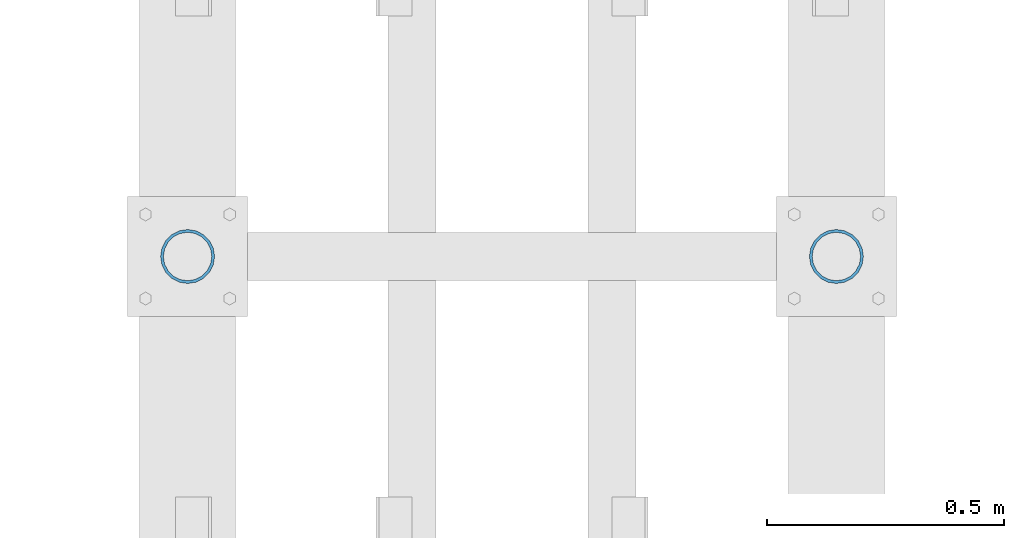
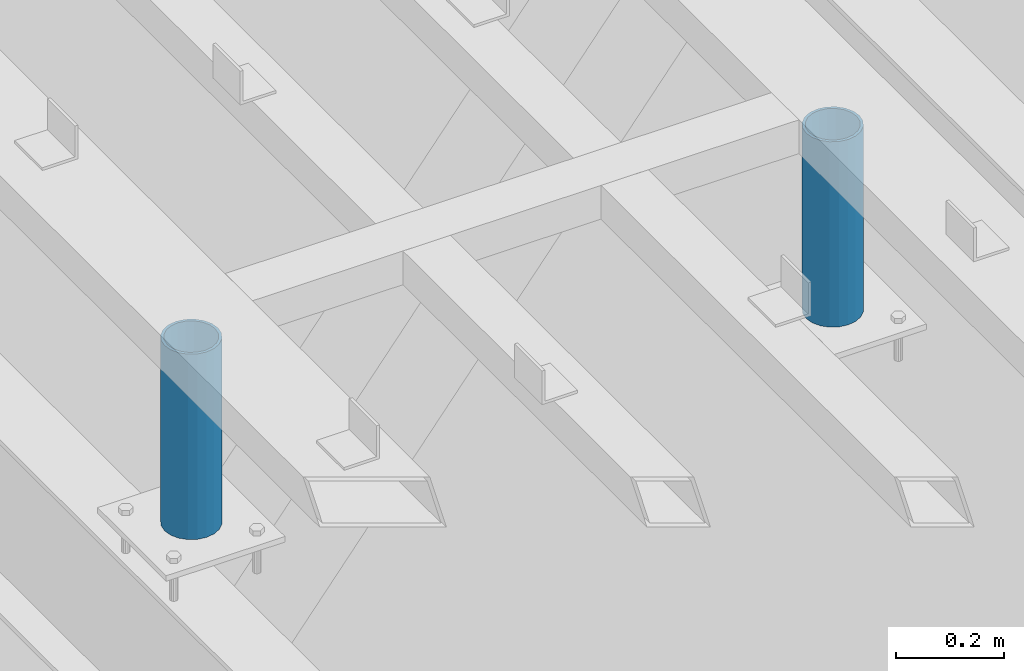
# One storey, part 502 of 1179: 2 columns, 1 element without a shape of its own.
"""IFC2X3 building model written with IfcOpenShell, lengths in millimetres."""

from ifc_helpers import new_model, si_unit, frame, origin_with_axes, place, context, subcontext, project, spatial, faceted_brep, material, type_object, element, aggregate, save


model = new_model("IFC2X3")

# Units and contexts
model_context = context("Model", 3, precision=1e-05, world=origin_with_axes())
body_context = subcontext(model_context, "Body", "Model", "MODEL_VIEW")
ifc_project = project(units=[si_unit("LENGTHUNIT", "METRE", prefix="MILLI"), si_unit("AREAUNIT", "SQUARE_METRE"), si_unit("VOLUMEUNIT", "CUBIC_METRE"), si_unit("MASSUNIT", "GRAM", prefix="KILO"), si_unit("TIMEUNIT", "SECOND"), si_unit("PLANEANGLEUNIT", "RADIAN"), si_unit("SOLIDANGLEUNIT", "STERADIAN"), si_unit("THERMODYNAMICTEMPERATUREUNIT", "DEGREE_CELSIUS"), si_unit("LUMINOUSINTENSITYUNIT", "LUMEN")], contexts=[model_context])

# Site, building, storey
site_placement = place(None, origin_with_axes())
site = spatial("IfcSite", under=ifc_project, at=site_placement, CompositionType="ELEMENT")
building_placement = place(site_placement, origin_with_axes())
building = spatial("IfcBuilding", under=site, at=building_placement, Name="Undefined", CompositionType="ELEMENT")
storey_placement = place(building_placement, origin_with_axes())
storey = spatial("IfcBuildingStorey", under=building, at=storey_placement, Name="Undefined", CompositionType="ELEMENT", Elevation=0.0)

# Assembly, columns
assembly_placement = place(storey_placement, origin_with_axes())
assembly = element("IfcElementAssembly", 1, at=assembly_placement, inside=storey, Name="FRAME", AssemblyPlace="NOTDEFINED", PredefinedType="RIGID_FRAME")
ifc_material = material()
column_type = type_object("IfcColumnType", Name="PIPE4SCH40", PredefinedType="NOTDEFINED")
column_1_placement = place(assembly_placement, frame((9652.0, 37794.5344873485, 13265.15), z_axis=(0.0, 1.0, 0.0), x_axis=(0.0, 0.0, 1.0)))
column_1 = element("IfcColumn", 2, at=column_1_placement, type_object=column_type, material=ifc_material, Name="COLUMN", ObjectType="PIPE4SCH40", context=body_context, shape_type="Brep", body=[
    faceted_brep([(0.0, -51.1301999999996, 0.0), (0.0, -48.6277098894752, 15.8001007257917), (419.099999999999, -48.6277098894752, 15.8001007257917), (419.099999999999, -51.1301999999996, 0.0), (0.0, -41.3652007257915, 30.0535775067619), (419.099999999999, -41.3652007257915, 30.0535775067619), (0.0, -30.0535775067656, 41.3652007257915), (419.099999999999, -30.0535775067656, 41.3652007257915), (0.0, -15.8001007257917, 48.6277098894716), (419.099999999999, -15.8001007257917, 48.6277098894716), (0.0, 0.0, 51.1301999999996), (419.099999999999, 0.0, 51.1301999999996), (0.0, 15.8001007257917, 48.6277098894716), (419.099999999999, 15.8001007257917, 48.6277098894716), (0.0, 30.0535775067656, 41.3652007257915), (419.099999999999, 30.0535775067656, 41.3652007257915), (0.0, 41.3652007257915, 30.0535775067619), (419.099999999999, 41.3652007257915, 30.0535775067619), (0.0, 48.6277098894752, 15.8001007257917), (419.099999999999, 48.6277098894752, 15.8001007257917), (0.0, 51.1301999999996, 0.0), (419.099999999999, 51.1301999999996, 0.0), (0.0, 48.6277098894752, -15.8001007257917), (419.099999999999, 48.6277098894752, -15.8001007257917), (0.0, 41.3652007257915, -30.0535775067619), (419.099999999999, 41.3652007257915, -30.0535775067619), (0.0, 30.0535775067656, -41.3652007257915), (419.099999999999, 30.0535775067656, -41.3652007257915), (0.0, 15.8001007257917, -48.6277098894716), (419.099999999999, 15.8001007257917, -48.6277098894716), (0.0, 0.0, -51.1301999999996), (419.099999999999, 0.0, -51.1301999999996), (0.0, -15.8001007257917, -48.6277098894716), (419.099999999999, -15.8001007257917, -48.6277098894716), (0.0, -30.0535775067656, -41.3652007257915), (419.099999999999, -30.0535775067656, -41.3652007257915), (0.0, -41.3652007257915, -30.0535775067619), (419.099999999999, -41.3652007257915, -30.0535775067619), (0.0, -48.6277098894752, -15.8001007257917), (419.099999999999, -48.6277098894752, -15.8001007257917), (0.0, -57.1500000000015, 0.0), (0.0, -54.3528799062697, -17.6603212285263), (419.099999999999, -54.3528799062697, -17.6603212285263), (419.099999999999, -57.1500000000015, 0.0), (0.0, -46.235321228527, -33.5919271685125), (419.099999999999, -46.235321228527, -33.5919271685125), (0.0, -33.5919271685161, -46.2353212285307), (419.099999999999, -33.5919271685161, -46.2353212285307), (0.0, -17.6603212285299, -54.3528799062697), (419.099999999999, -17.6603212285299, -54.3528799062697), (0.0, 0.0, -57.1500000000015), (419.099999999999, 0.0, -57.1500000000015), (0.0, 17.6603212285299, -54.3528799062697), (419.099999999999, 17.6603212285299, -54.3528799062697), (0.0, 33.5919271685161, -46.2353212285307), (419.099999999999, 33.5919271685161, -46.2353212285307), (0.0, 46.235321228527, -33.5919271685125), (419.099999999999, 46.235321228527, -33.5919271685125), (0.0, 54.3528799062697, -17.6603212285263), (419.099999999999, 54.3528799062697, -17.6603212285263), (0.0, 57.1500000000015, 0.0), (419.099999999999, 57.1500000000015, 0.0), (0.0, 54.3528799062697, 17.6603212285263), (419.099999999999, 54.3528799062697, 17.6603212285263), (0.0, 46.235321228527, 33.5919271685125), (419.099999999999, 46.235321228527, 33.5919271685125), (0.0, 33.5919271685161, 46.2353212285307), (419.099999999999, 33.5919271685161, 46.2353212285307), (0.0, 17.6603212285299, 54.3528799062697), (419.099999999999, 17.6603212285299, 54.3528799062697), (0.0, 0.0, 57.1500000000015), (419.099999999999, 0.0, 57.1500000000015), (0.0, -17.6603212285299, 54.3528799062697), (419.099999999999, -17.6603212285299, 54.3528799062697), (0.0, -33.5919271685161, 46.2353212285307), (419.099999999999, -33.5919271685161, 46.2353212285307), (0.0, -46.235321228527, 33.5919271685125), (419.099999999999, -46.235321228527, 33.5919271685125), (0.0, -54.3528799062697, 17.6603212285263), (419.099999999999, -54.3528799062697, 17.6603212285263)], [[[0, 1, 2, 3]], [[1, 4, 5, 2]], [[4, 6, 7, 5]], [[6, 8, 9, 7]], [[8, 10, 11, 9]], [[10, 12, 13, 11]], [[12, 14, 15, 13]], [[14, 16, 17, 15]], [[16, 18, 19, 17]], [[18, 20, 21, 19]], [[20, 22, 23, 21]], [[22, 24, 25, 23]], [[24, 26, 27, 25]], [[26, 28, 29, 27]], [[28, 30, 31, 29]], [[30, 32, 33, 31]], [[32, 34, 35, 33]], [[34, 36, 37, 35]], [[36, 38, 39, 37]], [[38, 0, 3, 39]], [[40, 41, 42, 43]], [[41, 44, 45, 42]], [[44, 46, 47, 45]], [[46, 48, 49, 47]], [[48, 50, 51, 49]], [[50, 52, 53, 51]], [[52, 54, 55, 53]], [[54, 56, 57, 55]], [[56, 58, 59, 57]], [[58, 60, 61, 59]], [[60, 62, 63, 61]], [[62, 64, 65, 63]], [[64, 66, 67, 65]], [[66, 68, 69, 67]], [[68, 70, 71, 69]], [[70, 72, 73, 71]], [[72, 74, 75, 73]], [[74, 76, 77, 75]], [[76, 78, 79, 77]], [[78, 40, 43, 79]], [[45, 47, 49, 51, 53, 55, 57, 59, 61, 63, 65, 67, 69, 71, 73, 75, 77, 79, 43, 42], [5, 7, 9, 11, 13, 15, 17, 19, 21, 23, 25, 27, 29, 31, 33, 35, 37, 39, 3, 2]], [[78, 76, 74, 72, 70, 68, 66, 64, 62, 60, 58, 56, 54, 52, 50, 48, 46, 44, 41, 40], [38, 36, 34, 32, 30, 28, 26, 24, 22, 20, 18, 16, 14, 12, 10, 8, 6, 4, 1, 0]]]),
])
column_2_placement = place(assembly_placement, frame((8280.4, 37794.5344873485, 13265.15), z_axis=(0.0, 1.0, 0.0), x_axis=(0.0, 0.0, 1.0)))
column_2 = element("IfcColumn", 3, at=column_2_placement, type_object=column_type, material=ifc_material, Name="COLUMN", ObjectType="PIPE4SCH40", context=body_context, shape_type="Brep", body=[
    faceted_brep([(0.0, -51.1301999999996, 0.0), (0.0, -48.6277098894752, 15.8001007257917), (419.099999999999, -48.6277098894752, 15.8001007257917), (419.099999999999, -51.1301999999996, 0.0), (0.0, -41.3652007257915, 30.0535775067619), (419.099999999999, -41.3652007257915, 30.0535775067619), (0.0, -30.0535775067656, 41.3652007257915), (419.099999999999, -30.0535775067656, 41.3652007257915), (0.0, -15.8001007257917, 48.6277098894716), (419.099999999999, -15.8001007257917, 48.6277098894716), (0.0, 0.0, 51.1301999999996), (419.099999999999, 0.0, 51.1301999999996), (0.0, 15.8001007257917, 48.6277098894716), (419.099999999999, 15.8001007257917, 48.6277098894716), (0.0, 30.0535775067656, 41.3652007257915), (419.099999999999, 30.0535775067656, 41.3652007257915), (0.0, 41.3652007257915, 30.0535775067619), (419.099999999999, 41.3652007257915, 30.0535775067619), (0.0, 48.6277098894752, 15.8001007257917), (419.099999999999, 48.6277098894752, 15.8001007257917), (0.0, 51.1301999999996, 0.0), (419.099999999999, 51.1301999999996, 0.0), (0.0, 48.6277098894752, -15.8001007257917), (419.099999999999, 48.6277098894752, -15.8001007257917), (0.0, 41.3652007257915, -30.0535775067619), (419.099999999999, 41.3652007257915, -30.0535775067619), (0.0, 30.0535775067656, -41.3652007257915), (419.099999999999, 30.0535775067656, -41.3652007257915), (0.0, 15.8001007257917, -48.6277098894716), (419.099999999999, 15.8001007257917, -48.6277098894716), (0.0, 0.0, -51.1301999999996), (419.099999999999, 0.0, -51.1301999999996), (0.0, -15.8001007257917, -48.6277098894716), (419.099999999999, -15.8001007257917, -48.6277098894716), (0.0, -30.0535775067656, -41.3652007257915), (419.099999999999, -30.0535775067656, -41.3652007257915), (0.0, -41.3652007257915, -30.0535775067619), (419.099999999999, -41.3652007257915, -30.0535775067619), (0.0, -48.6277098894752, -15.8001007257917), (419.099999999999, -48.6277098894752, -15.8001007257917), (0.0, -57.1500000000015, 0.0), (0.0, -54.3528799062697, -17.6603212285263), (419.099999999999, -54.3528799062697, -17.6603212285263), (419.099999999999, -57.1500000000015, 0.0), (0.0, -46.235321228527, -33.5919271685125), (419.099999999999, -46.235321228527, -33.5919271685125), (0.0, -33.5919271685161, -46.2353212285307), (419.099999999999, -33.5919271685161, -46.2353212285307), (0.0, -17.6603212285299, -54.3528799062697), (419.099999999999, -17.6603212285299, -54.3528799062697), (0.0, 0.0, -57.1500000000015), (419.099999999999, 0.0, -57.1500000000015), (0.0, 17.6603212285299, -54.3528799062697), (419.099999999999, 17.6603212285299, -54.3528799062697), (0.0, 33.5919271685161, -46.2353212285307), (419.099999999999, 33.5919271685161, -46.2353212285307), (0.0, 46.235321228527, -33.5919271685125), (419.099999999999, 46.235321228527, -33.5919271685125), (0.0, 54.3528799062697, -17.6603212285263), (419.099999999999, 54.3528799062697, -17.6603212285263), (0.0, 57.1500000000015, 0.0), (419.099999999999, 57.1500000000015, 0.0), (0.0, 54.3528799062697, 17.6603212285263), (419.099999999999, 54.3528799062697, 17.6603212285263), (0.0, 46.235321228527, 33.5919271685125), (419.099999999999, 46.235321228527, 33.5919271685125), (0.0, 33.5919271685161, 46.2353212285307), (419.099999999999, 33.5919271685161, 46.2353212285307), (0.0, 17.6603212285299, 54.3528799062697), (419.099999999999, 17.6603212285299, 54.3528799062697), (0.0, 0.0, 57.1500000000015), (419.099999999999, 0.0, 57.1500000000015), (0.0, -17.6603212285299, 54.3528799062697), (419.099999999999, -17.6603212285299, 54.3528799062697), (0.0, -33.5919271685161, 46.2353212285307), (419.099999999999, -33.5919271685161, 46.2353212285307), (0.0, -46.235321228527, 33.5919271685125), (419.099999999999, -46.235321228527, 33.5919271685125), (0.0, -54.3528799062697, 17.6603212285263), (419.099999999999, -54.3528799062697, 17.6603212285263)], [[[0, 1, 2, 3]], [[1, 4, 5, 2]], [[4, 6, 7, 5]], [[6, 8, 9, 7]], [[8, 10, 11, 9]], [[10, 12, 13, 11]], [[12, 14, 15, 13]], [[14, 16, 17, 15]], [[16, 18, 19, 17]], [[18, 20, 21, 19]], [[20, 22, 23, 21]], [[22, 24, 25, 23]], [[24, 26, 27, 25]], [[26, 28, 29, 27]], [[28, 30, 31, 29]], [[30, 32, 33, 31]], [[32, 34, 35, 33]], [[34, 36, 37, 35]], [[36, 38, 39, 37]], [[38, 0, 3, 39]], [[40, 41, 42, 43]], [[41, 44, 45, 42]], [[44, 46, 47, 45]], [[46, 48, 49, 47]], [[48, 50, 51, 49]], [[50, 52, 53, 51]], [[52, 54, 55, 53]], [[54, 56, 57, 55]], [[56, 58, 59, 57]], [[58, 60, 61, 59]], [[60, 62, 63, 61]], [[62, 64, 65, 63]], [[64, 66, 67, 65]], [[66, 68, 69, 67]], [[68, 70, 71, 69]], [[70, 72, 73, 71]], [[72, 74, 75, 73]], [[74, 76, 77, 75]], [[76, 78, 79, 77]], [[78, 40, 43, 79]], [[45, 47, 49, 51, 53, 55, 57, 59, 61, 63, 65, 67, 69, 71, 73, 75, 77, 79, 43, 42], [5, 7, 9, 11, 13, 15, 17, 19, 21, 23, 25, 27, 29, 31, 33, 35, 37, 39, 3, 2]], [[78, 76, 74, 72, 70, 68, 66, 64, 62, 60, 58, 56, 54, 52, 50, 48, 46, 44, 41, 40], [38, 36, 34, 32, 30, 28, 26, 24, 22, 20, 18, 16, 14, 12, 10, 8, 6, 4, 1, 0]]]),
])
aggregate(assembly, [column_1, column_2])

save(model, "model.ifc")
